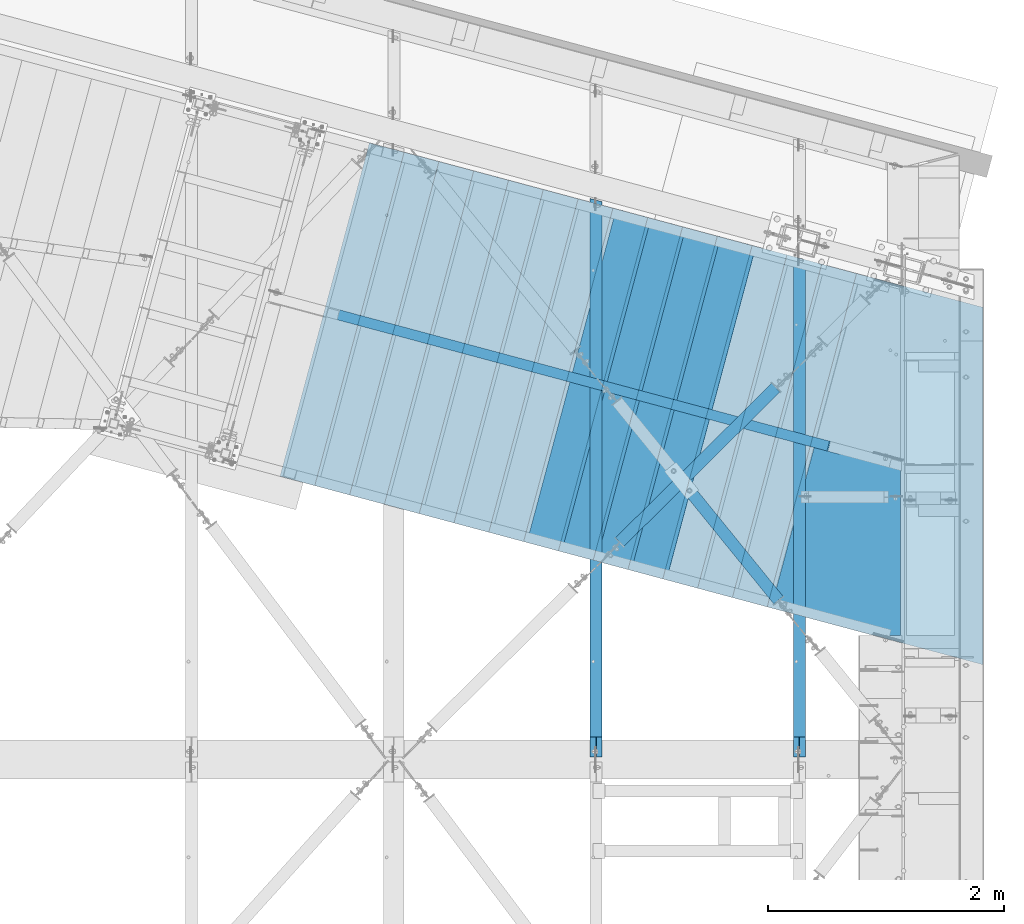
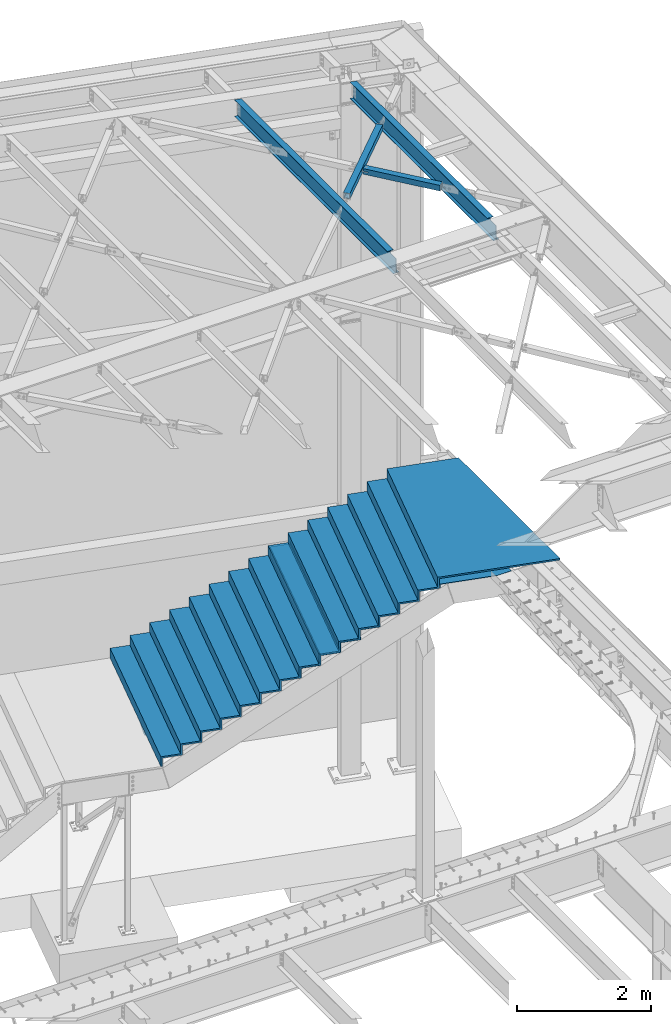
# One storey, part 1170 of 1763: 10 beams, 1 member, 7 elements without a shape of their own.
"""IFC2X3 building model written with IfcOpenShell, lengths in millimetres."""

from ifc_helpers import new_model, si_unit, frame, origin_with_axes, place, context, subcontext, project, spatial, faceted_brep, material, type_object, element, aggregate, save


model = new_model("IFC2X3")

# Units and contexts
model_context = context("Model", 3, precision=1e-05, world=origin_with_axes())
body_context = subcontext(model_context, "Body", "Model", "MODEL_VIEW")
ifc_project = project(units=[si_unit("LENGTHUNIT", "METRE", prefix="MILLI"), si_unit("AREAUNIT", "SQUARE_METRE"), si_unit("VOLUMEUNIT", "CUBIC_METRE"), si_unit("MASSUNIT", "GRAM", prefix="KILO"), si_unit("TIMEUNIT", "SECOND"), si_unit("PLANEANGLEUNIT", "RADIAN"), si_unit("SOLIDANGLEUNIT", "STERADIAN"), si_unit("THERMODYNAMICTEMPERATUREUNIT", "DEGREE_CELSIUS"), si_unit("LUMINOUSINTENSITYUNIT", "LUMEN")], contexts=[model_context])

# Site, building, storey
site_placement = place(None, origin_with_axes())
site = spatial("IfcSite", under=ifc_project, at=site_placement, CompositionType="ELEMENT")
building_placement = place(site_placement, origin_with_axes())
building = spatial("IfcBuilding", under=site, at=building_placement, Name="Undefined", CompositionType="ELEMENT")
storey_placement = place(building_placement, origin_with_axes())
storey = spatial("IfcBuildingStorey", under=building, at=storey_placement, Name="Undefined", CompositionType="ELEMENT", Elevation=0.0)

# Assembly, beam
assembly_1_placement = place(storey_placement, origin_with_axes())
assembly_1 = element("IfcElementAssembly", 1, at=assembly_1_placement, inside=storey, Name="BENT_PLATE", AssemblyPlace="NOTDEFINED", PredefinedType="RIGID_FRAME")
ifc_material_1 = material(Name="STEEL/A36")
beam_type_1 = type_object("IfcBeamType", PredefinedType="NOTDEFINED")
beam_1_placement = place(assembly_1_placement, frame((-21003.2672409802, 59253.1163155108, 5251.44988239311), z_axis=(-0.258865912030778, -0.965913267114844, 3.00823476209188e-08), x_axis=(0.0, 0.0, -1.0)))
beam_1 = element("IfcBeam", 2, at=beam_1_placement, type_object=beam_type_1, material=ifc_material_1, Name="BENT_PLATE", context=body_context, shape_type="Brep", body=[
    faceted_brep([(57.6506451250798, -1650.94311464479, 720.710372407564), (47.6245760248121, -1650.9436488109, 720.710372254034), (47.6251582457617, -1650.92979207974, -720.73962767957), (57.6501590183007, -1650.93032624145, -720.73962753555), (121.44339776049, -1650.93032622719, -720.739649048715), (121.443883867259, -1650.94311463053, 720.710350894398), (121.443397758396, -1641.40532622756, -720.739564543852), (121.443883865164, -1641.41811463091, 720.710435399262), (57.6501590162061, -1641.40532624182, -720.739543030686), (57.1501590162088, -1641.40479207806, -720.739539327413), (57.1495767952592, -1641.41864880922, 720.710460606191), (57.6506451229843, -1641.41811464516, 720.710456912435), (57.1496481931354, -758.731268997537, 720.718291722325), (47.6246481931375, -758.731253575555, 720.71828787517), (57.1496908737008, -533.074830259327, 660.242095972302), (47.6246908737003, -533.07483026143, 660.242096258822), (47.6252187294413, -903.173937115156, -720.732993662728), (57.15021872944, -903.173936005202, -720.73298981542)], [[[0, 1, 2, 3, 4, 5]], [[5, 4, 6, 7]], [[8, 9, 10, 11, 7, 6]], [[1, 0, 5, 7, 11, 10, 12, 13]], [[13, 12, 14, 15]], [[2, 1, 13, 15, 16]], [[9, 8, 6, 4, 3, 2, 16, 17]], [[12, 10, 9, 17, 14]], [[16, 15, 14, 17]]]),
])
aggregate(assembly_1, [beam_1])

assembly_2_placement = place(storey_placement, origin_with_axes())
assembly_2 = element("IfcElementAssembly", 3, at=assembly_2_placement, inside=storey, Name="H. BRACE", AssemblyPlace="NOTDEFINED", PredefinedType="RIGID_FRAME")
ifc_material_2 = material()
beam_type_2 = type_object("IfcBeamType", Name="HSS4X4X3/8", PredefinedType="NOTDEFINED")
beam_2_placement = place(assembly_2_placement, frame((-24264.6496174484, 59345.3336021854, 12371.3875), z_axis=(0.0, 0.0, 1.0), x_axis=(0.711007281992602, 0.703184644992688, 0.0)))
beam_2 = element("IfcBeam", 4, at=beam_2_placement, type_object=beam_type_2, material=ifc_material_2, Name="H. BRACE", ObjectType="HSS4X4X3/8", context=body_context, shape_type="Brep", body=[
    faceted_brep([(950.85467057893, 50.799999998344, 6.35000000000218), (949.917828152189, 41.2749999983498, 6.35000000000218), (949.917828152189, 41.2749999983498, -6.34999999999854), (950.85467057893, 50.799999998344, -6.34999999999854), (1090.2919366415, 41.2749999981024, -6.34999999999854), (1091.22877922558, 50.7999999981039, -6.34999999999854), (1090.2919366415, 41.2749999981024, 6.35000000000218), (1091.22877922558, 50.7999999981039, 6.35000000000218), (941.798527120362, -41.2750000016822, 6.35000000000218), (940.861684693613, -50.8000000016764, 6.35000000000218), (940.861684693613, -50.8000000016764, -6.34999999999854), (941.798527120362, -41.2750000016822, -6.34999999999854), (1081.23579166203, -50.800000001931, -6.34999999999854), (1082.17263424611, -41.2750000019296, -6.34999999999854), (1081.23579166203, -50.800000001931, 6.35000000000218), (1082.17263424611, -41.2750000019296, 6.35000000000218), (280.742643683188, -50.8000000005195, -50.7999999999993), (280.742643682926, 50.7999999995227, -50.7999999999993), (2136.20681555194, 50.7999999962631, -50.7999999999993), (2136.2068155522, -50.8000000037864, -50.7999999999993), (280.742643682926, 50.7999999995227, 50.7999999999993), (280.742643683188, -50.8000000005195, 50.7999999999993), (2136.2068155522, -50.8000000037864, 50.7999999999993), (2136.20681555194, 50.7999999962631, 50.7999999999993), (280.742643682952, 41.2749999995285, 41.2749999999996), (280.742643683163, -41.275000000518, 41.2749999999996), (280.742643683163, -41.275000000518, -41.2749999999996), (280.742643682952, 41.2749999995285, -41.2749999999996), (2136.20681555197, 41.2749999962543, -41.2749999999996), (2136.20681555197, 41.2749999962543, 41.2749999999996), (2136.20681555218, -41.275000003785, 41.2749999999996), (2136.20681555218, -41.275000003785, -41.2749999999996)], [[[0, 1, 2, 3]], [[3, 2, 4, 5]], [[5, 4, 6, 7]], [[7, 6, 1, 0]], [[8, 9, 10, 11]], [[11, 10, 12, 13]], [[13, 12, 14, 15]], [[15, 14, 9, 8]], [[16, 17, 18, 19]], [[20, 21, 22, 23]], [[17, 20, 23, 18], [3, 5, 7, 0]], [[16, 21, 20, 17], [24, 25, 26, 27]], [[24, 27, 28, 29], [2, 1, 6, 4]], [[25, 24, 29, 30]], [[26, 25, 30, 31], [11, 13, 15, 8]], [[27, 26, 31, 28]], [[22, 19, 18, 23], [30, 29, 28, 31]], [[21, 16, 19, 22], [10, 9, 14, 12]]]),
])
aggregate(assembly_2, [beam_2])

assembly_3_placement = place(storey_placement, origin_with_axes())
assembly_3 = element("IfcElementAssembly", 5, at=assembly_3_placement, inside=storey, Name="H. BRACE", AssemblyPlace="NOTDEFINED", PredefinedType="RIGID_FRAME")
beam_3_placement = place(assembly_3_placement, frame((-22546.3296174484, 58832.8427732481, 12371.3875), z_axis=(0.0, 0.0, 1.0), x_axis=(-0.630211709758953, 0.776423338702989, 0.0)))
beam_3 = element("IfcBeam", 6, at=beam_3_placement, type_object=beam_type_2, material=ifc_material_2, Name="H. BRACE", ObjectType="HSS4X4X3/8", context=body_context, shape_type="Brep", body=[
    faceted_brep([(1511.46674810058, -50.8000000034663, -6.35000000000036), (1511.46674810056, -41.2750000034757, -6.35000000000036), (1426.2821400689, -41.2750000032756, -6.35000000000036), (1426.28213914244, -50.8000000032662, -6.35000000000036), (1426.2821400689, -41.2750000032756, 6.35000000000036), (1426.28213914244, -50.8000000032662, 6.35000000000036), (1511.46674810058, -50.8000000034663, 6.35000000000036), (1511.46674810056, -41.2750000034757, 6.35000000000036), (1511.46674810037, 41.2749999964653, -6.35000000000036), (1511.46674810035, 50.7999999964522, -6.35000000000036), (1426.28214902463, 50.799999996656, -6.35000000000036), (1426.28214809817, 41.2749999966654, -6.35000000000036), (1426.28214902463, 50.799999996656, 6.35000000000036), (1426.28214809817, 41.2749999966654, 6.35000000000036), (1511.46674810037, 41.2749999964653, 6.35000000000036), (1511.46674810035, 50.7999999964522, 6.35000000000036), (281.348620558667, -41.2750000006235, 41.2749999999996), (281.348620558478, 41.2749999993139, 41.2749999999996), (1511.46674810037, 41.2749999964653, 41.2749999999996), (1511.46674810056, -41.2750000034757, 41.2749999999996), (1511.46674810056, -41.2750000034757, -41.2749999999996), (281.348620558667, -41.2750000006235, -41.2749999999996), (281.348620558478, 41.2749999993139, -41.2749999999996), (1511.46674810037, 41.2749999964653, -41.2749999999996), (281.348620558689, -50.8000000006214, -50.7999999999993), (281.348620558689, -50.8000000006214, 50.7999999999993), (281.348620558456, 50.7999999993044, 50.7999999999993), (281.348620558456, 50.7999999993044, -50.7999999999993), (1511.46674810058, -50.8000000034663, 50.7999999999993), (1511.46674810035, 50.7999999964522, 50.7999999999993), (1511.46674810035, 50.7999999964522, -50.7999999999993), (1511.46674810058, -50.8000000034663, -50.7999999999993)], [[[0, 1, 2, 3]], [[3, 2, 4, 5]], [[6, 5, 4, 7]], [[8, 9, 10, 11]], [[11, 10, 12, 13]], [[14, 13, 12, 15]], [[16, 17, 18, 19]], [[2, 1, 20, 21, 16, 19, 7, 4]], [[22, 21, 20, 23]], [[24, 25, 26, 27], [17, 16, 21, 22]], [[26, 25, 28, 29]], [[19, 18, 14, 15, 29, 28, 6, 7]], [[10, 9, 30, 27, 26, 29, 15, 12]], [[24, 27, 30, 31]], [[28, 25, 24, 31, 0, 3, 5, 6]], [[31, 30, 9, 8, 23, 20, 1, 0]], [[18, 17, 22, 23, 8, 11, 13, 14]]]),
])
aggregate(assembly_3, [beam_3])

# Assembly, member
assembly_4_placement = place(storey_placement, origin_with_axes())
assembly_4 = element("IfcElementAssembly", 7, at=assembly_4_placement, inside=storey, Name="STRINGER", AssemblyPlace="NOTDEFINED", PredefinedType="RIGID_FRAME")
member_type = type_object("IfcMemberType", Name="C15X33.9", PredefinedType="NOTDEFINED")
member_placement = place(assembly_4_placement, frame((-21969.937005167, 60264.8820691465, 5169.45011935172), z_axis=(0.486695708763338, -0.13043503320458, -0.863778900636194), x_axis=(-0.834335499956352, 0.223602912988303, -0.50387102597364)))
member = element("IfcMember", 8, at=member_placement, type_object=member_type, material=ifc_material_1, Name="STRINGER", ObjectType="C15X33.9", context=body_context, shape_type="Brep", body=[
    faceted_brep([(377.770677480883, -40.096616847979, 181.305096366556), (377.770677497621, 33.3374999985899, 181.305096366563), (374.463192616367, 33.3374999986336, 169.070972499958), (5371.12157756641, -40.0966168786908, -181.305096368524), (5371.12157758316, 33.3374999856896, -181.305096368513), (5374.42906248087, 33.337499985646, -169.070972498947), (5462.11376655698, -42.8625000156244, 190.500000000822), (5468.8001694057, -42.8625000156244, 181.765892500833), (5469.15293224548, -40.0966168798332, 181.305096370408), (5469.15293226223, 33.3374999845473, 181.305096370415), (5462.11376657645, 42.5324036149832, 190.500000000829), (5359.11074327314, 42.532403616191, -190.49999999893), (5358.76879646806, 42.8624999857711, -190.499999998934), (5461.77181977136, 42.8624999845633, 190.500000000833), (5465.84544736449, 33.3374999845837, 169.070972500849), (5370.51966304915, -42.8625000144748, -181.765892498945), (5359.11074325368, -42.8625000144166, -190.499999998941), (286.778488966, -42.8625000004322, -190.499999999829), (280.092086109009, -42.8625000004249, -181.765892499836), (279.739323267782, -40.096616846844, -181.305096366446), (279.739323284521, 33.3374999997395, -181.305096366439), (286.77848898547, 42.532403633144, -190.499999999818), (389.781511800851, 42.5324036319507, 190.499999999945), (390.123458602906, 42.8624999985623, 190.499999999945), (287.120435787525, 42.8624999997628, -190.499999999818), (283.046808165778, 33.3374999997031, -169.070972499834), (378.372592000011, -42.8625000015818, 181.765892499941), (389.781511781377, -42.8625000016327, 190.499999999938)], [[[0, 1, 2]], [[3, 4, 5]], [[6, 7, 8, 9, 10]], [[4, 11, 12, 13, 10, 9, 14, 5]], [[3, 15, 16, 11, 4]], [[17, 18, 19, 20, 21]], [[1, 22, 23, 24, 21, 20, 25, 2]], [[0, 26, 27, 22, 1]], [[24, 23, 13, 12]], [[13, 23, 22, 27, 6, 10]], [[27, 26, 7, 6]], [[26, 0, 2, 14, 8, 7]], [[2, 25, 5, 14]], [[5, 25, 19, 18, 15, 3]], [[18, 17, 16, 15]], [[16, 17, 21, 24, 12, 11]], [[8, 14, 9]], [[19, 25, 20]]]),
])

# Assembly, beam
assembly_5_placement = place(storey_placement, origin_with_axes())
assembly_5 = element("IfcElementAssembly", 9, at=assembly_5_placement, inside=storey, Name="BEAM", AssemblyPlace="NOTDEFINED", PredefinedType="RIGID_FRAME")
ifc_material_3 = material(Name="STEEL/A992")
beam_type_3 = type_object("IfcBeamType", Name="W12X16", PredefinedType="NOTDEFINED")
beam_4_placement = place(assembly_5_placement, frame((-22546.3296174484, 57702.45, 12293.6), z_axis=(0.0, 0.0, 1.0), x_axis=(0.0, 1.0, 0.0)))
beam_4 = element("IfcBeam", 10, at=beam_4_placement, type_object=beam_type_3, material=ifc_material_3, Name="BEAM", ObjectType="W12X16", context=body_context, shape_type="Brep", body=[
    faceted_brep([(179.387500190729, -3.17500000000291, 114.040001678466), (179.387500190729, 3.17500000000291, 114.040001678466), (20.6374999999971, 3.17500000000291, 114.040001678466), (20.6374999999971, -3.17500000000291, 114.040001678466), (184.247579708775, -3.17500000000291, 115.006731601054), (184.247579708775, 3.17500000000291, 115.006731601054), (188.367756176929, -3.17500000000291, 117.759745501531), (188.367756176929, 3.17500000000291, 117.759745501531), (191.120770077403, -3.17500000000291, 121.879921969685), (191.120770077403, 3.17500000000291, 121.879921969685), (192.087499999994, -3.17500000000291, 126.740001487731), (192.087499999994, 3.17500000000291, 126.740001487731), (192.087499999994, -50.8000000000029, 152.4), (192.087499999994, 50.8000000000029, 152.4), (192.087499999994, 50.8000000000029, 146.049999999999), (192.087499999994, 3.17500000000291, 146.049999999999), (192.087499999994, -3.17500000000291, 146.049999999999), (192.087499999994, -50.8000000000029, 146.049999999999), (20.637499999335, -3.17500000023574, -146.050000000019), (20.637499999335, -50.8000000002503, -146.05000000003), (4258.11735211471, -50.7999999999993, -146.049999999999), (4270.88090913396, -3.17499999999927, -146.049999999999), (20.637499999335, -50.8000000002576, -152.400000000032), (4258.11735211471, -50.7999999999993, -152.4), (20.637499999335, 50.7999999997701, -152.400000000003), (4285.34627375577, 50.7999999999993, -152.4), (20.637499999335, 50.7999999997774, -146.050000000005), (20.637499999335, 3.17499999977008, -146.050000000016), (4272.58271673653, 3.17499999999927, -146.049999999999), (4285.34627375577, 50.7999999999993, -146.049999999999), (4272.58271673653, 3.17499999999927, 146.049999999999), (4285.34627375577, 50.7999999999993, 146.049999999999), (4285.34627375577, 50.7999999999993, 152.4), (4258.11735211471, -50.7999999999993, 152.4), (4258.11735211471, -50.7999999999993, 146.049999999999), (4270.88090913396, -3.17499999999927, 146.049999999999)], [[[0, 1, 2, 3]], [[4, 5, 1, 0]], [[6, 7, 5, 4]], [[8, 9, 7, 6]], [[10, 11, 9, 8]], [[12, 13, 14, 15, 11, 10, 16, 17]], [[18, 19, 20, 21]], [[19, 22, 23, 20]], [[22, 24, 25, 23]], [[26, 27, 28, 29]], [[24, 26, 29, 25]], [[28, 30, 31, 32, 33, 34, 35, 21, 20, 23, 25, 29]], [[34, 33, 12, 17]], [[35, 34, 17, 16]], [[8, 6, 4, 0, 3, 18, 21, 35, 16, 10]], [[27, 26, 24, 22, 19, 18, 3, 2]], [[30, 28, 27, 2, 1, 5, 7, 9, 11, 15]], [[31, 30, 15, 14]], [[32, 31, 14, 13]], [[33, 32, 13, 12]]]),
])
aggregate(assembly_5, [beam_4])

assembly_6_placement = place(storey_placement, origin_with_axes())
assembly_6 = element("IfcElementAssembly", 11, at=assembly_6_placement, inside=storey, Name="BEAM", AssemblyPlace="NOTDEFINED", PredefinedType="RIGID_FRAME")
beam_5_placement = place(assembly_6_placement, frame((-24264.6496174484, 57702.45, 12293.6), z_axis=(0.0, 0.0, 1.0), x_axis=(0.0, 1.0, 0.0)))
beam_5 = element("IfcBeam", 12, at=beam_5_placement, type_object=beam_type_3, material=ifc_material_3, Name="BEAM", ObjectType="W12X16", context=body_context, shape_type="Brep", body=[
    faceted_brep([(20.637499999335, -3.17500000023574, -146.050000000019), (20.637499999335, -50.8000000002503, -146.05000000003), (4718.54398888365, -50.7999999999993, -146.049999999999), (4731.30506917194, -3.17499999999927, -146.049999999999), (20.637499999335, -50.8000000002576, -152.400000000032), (4718.54398888365, -50.7999999999993, -152.4), (20.637499999335, 50.7999999997701, -152.400000000003), (4745.76762683201, 50.7999999999993, -152.4), (20.637499999335, 50.7999999997774, -146.050000000005), (4745.76762683201, 50.7999999999993, -146.049999999999), (4733.00654654371, 3.17499999999927, -146.049999999999), (4733.00654654371, 3.17499999999927, 146.049999999999), (4745.76762683201, 50.7999999999993, 146.049999999999), (4745.76762683201, 50.7999999999993, 152.4), (4718.54398888365, -50.7999999999993, 152.4), (4718.54398888365, -50.7999999999993, 146.049999999999), (4731.30506917194, -3.17499999999927, 146.049999999999), (20.637499999335, 3.17499999977008, -146.050000000016), (184.247579708775, -3.17500000000291, 115.006731601054), (184.247579708775, 3.17500000000291, 115.006731601054), (179.387500190729, 3.17500000000291, 114.040001678466), (179.387500190729, -3.17500000000291, 114.040001678466), (188.367756176929, -3.17500000000291, 117.759745501531), (188.367756176929, 3.17500000000291, 117.759745501531), (191.120770077403, -3.17500000000291, 121.879921969685), (191.120770077403, 3.17500000000291, 121.879921969685), (192.087499999994, -3.17500000000291, 126.740001487731), (192.087499999994, 3.17500000000291, 126.740001487731), (20.6374999999971, 3.17500000000291, 114.040001678466), (192.087499999994, 3.17500000000291, 146.049999999999), (192.087499999994, 50.8000000000029, 146.049999999999), (192.087499999994, 50.8000000000029, 152.4), (192.087499999994, -50.8000000000029, 152.4), (192.087499999994, -50.8000000000029, 146.049999999999), (192.087499999994, -3.17500000000291, 146.049999999999), (20.6374999999971, -3.17500000000291, 114.040001678466)], [[[0, 1, 2, 3]], [[1, 4, 5, 2]], [[4, 6, 7, 5]], [[6, 8, 9, 7]], [[10, 11, 12, 13, 14, 15, 16, 3, 2, 5, 7, 9]], [[8, 17, 10, 9]], [[18, 19, 20, 21]], [[22, 23, 19, 18]], [[24, 25, 23, 22]], [[26, 27, 25, 24]], [[11, 10, 17, 28, 20, 19, 23, 25, 27, 29]], [[12, 11, 29, 30]], [[13, 12, 30, 31]], [[14, 13, 31, 32]], [[15, 14, 32, 33]], [[16, 15, 33, 34]], [[32, 31, 30, 29, 27, 26, 34, 33]], [[24, 22, 18, 21, 35, 0, 3, 16, 34, 26]], [[17, 8, 6, 4, 1, 0, 35, 28]], [[21, 20, 28, 35]]]),
])
aggregate(assembly_6, [beam_5])

# Beam
beam_type_4 = type_object("IfcBeamType", PredefinedType="NOTDEFINED")
beam_6_placement = place(assembly_4_placement, frame((-23291.2087596942, 60632.0165994589, 4641.85004577672), z_axis=(-0.258865912030778, -0.965913267114844, 3.00823476209188e-08), x_axis=(0.0, 0.0, -1.0)))
beam_6 = element("IfcBeam", 13, at=beam_6_placement, type_object=beam_type_4, material=ifc_material_1, Name="BENT_PLATE", context=body_context, shape_type="Brep", body=[
    faceted_brep([(1.9117578631267e-09, -1.5875000009255, -1460.49999999993), (-1.18325260700658e-09, -1.58749999909924, 1460.49999999992), (-1.9117578631267e-09, 1.58750000090367, 1460.49999999991), (1.18234311230481e-09, 1.58749999907741, -1460.49999999993), (50.7999999972071, 1.58750001260341, 1460.50000000007), (50.800000002233, 1.58750001077715, -1460.49999999979), (47.6250000029295, -1.58749998995336, -1460.4999999998), (47.6249999979027, -1.58749998812709, 1460.50000000005), (50.8000000657603, -306.387503397986, 1460.50000000045), (50.8000000687034, -306.387503401733, -1460.49999999939), (47.6250000693999, -309.562503402434, -1460.4999999994), (47.6250000664559, -309.562503398687, 1460.50000000045), (222.250000065187, -306.387503360114, 1460.50000000094), (222.250000068131, -306.387503363934, -1460.49999999891), (222.250000065887, -309.562503360117, 1460.50000000094), (222.250000068831, -309.562503363937, -1460.4999999989)], [[[0, 1, 2, 3]], [[3, 2, 4, 5]], [[1, 0, 6, 7]], [[5, 4, 8, 9]], [[7, 6, 10, 11]], [[9, 8, 12, 13]], [[8, 4, 2, 1, 7, 11, 14, 12]], [[11, 10, 15, 14]], [[10, 6, 0, 3, 5, 9, 13, 15]], [[14, 15, 13, 12]]]),
])

beam_7_placement = place(assembly_4_placement, frame((-23585.6191610753, 60710.918939513, 4464.04999694859), z_axis=(-0.258865912030778, -0.965913267114844, 3.00823476209188e-08), x_axis=(0.0, 0.0, -1.0)))
beam_7 = element("IfcBeam", 14, at=beam_7_placement, type_object=beam_type_4, material=ifc_material_1, Name="BENT_PLATE", context=body_context, shape_type="Brep", body=[
    faceted_brep([(1.9117578631267e-09, -1.5875000009255, -1460.49999999993), (-1.18325260700658e-09, -1.58749999909924, 1460.49999999992), (-1.9117578631267e-09, 1.58750000090367, 1460.49999999991), (1.18234311230481e-09, 1.58749999907741, -1460.49999999993), (50.7999999972071, 1.58750001260341, 1460.50000000007), (50.800000002233, 1.58750001077715, -1460.49999999979), (47.6250000029295, -1.58749998995336, -1460.4999999998), (47.6249999979027, -1.58749998812709, 1460.50000000005), (50.8000000657603, -306.387503397986, 1460.50000000045), (50.8000000687034, -306.387503401733, -1460.49999999939), (47.6250000693999, -309.562503402434, -1460.4999999994), (47.6250000664559, -309.562503398687, 1460.50000000045), (222.250000065187, -306.387503360114, 1460.50000000094), (222.250000068131, -306.387503363934, -1460.49999999891), (222.250000065887, -309.562503360117, 1460.50000000094), (222.250000068831, -309.562503363937, -1460.4999999989)], [[[0, 1, 2, 3]], [[3, 2, 4, 5]], [[1, 0, 6, 7]], [[5, 4, 8, 9]], [[7, 6, 10, 11]], [[9, 8, 12, 13]], [[8, 4, 2, 1, 7, 11, 14, 12]], [[11, 10, 15, 14]], [[10, 6, 0, 3, 5, 9, 13, 15]], [[14, 15, 13, 12]]]),
])

beam_8_placement = place(assembly_4_placement, frame((-23880.0295624563, 60789.8212795671, 4286.24994812047), z_axis=(-0.258865912030778, -0.965913267114844, 3.00823476209188e-08), x_axis=(0.0, 0.0, -1.0)))
beam_8 = element("IfcBeam", 15, at=beam_8_placement, type_object=beam_type_4, material=ifc_material_1, Name="BENT_PLATE", context=body_context, shape_type="Brep", body=[
    faceted_brep([(1.9117578631267e-09, -1.5875000009255, -1460.49999999993), (-1.18325260700658e-09, -1.58749999909924, 1460.49999999992), (-1.9117578631267e-09, 1.58750000090367, 1460.49999999991), (1.18234311230481e-09, 1.58749999907741, -1460.49999999993), (50.7999999972071, 1.58750001260341, 1460.50000000007), (50.800000002233, 1.58750001077715, -1460.49999999979), (47.6250000029295, -1.58749998995336, -1460.4999999998), (47.6249999979027, -1.58749998812709, 1460.50000000005), (50.8000000657603, -306.387503397986, 1460.50000000045), (50.8000000687034, -306.387503401733, -1460.49999999939), (47.6250000693999, -309.562503402434, -1460.4999999994), (47.6250000664559, -309.562503398687, 1460.50000000045), (222.250000065187, -306.387503360114, 1460.50000000094), (222.250000068131, -306.387503363934, -1460.49999999891), (222.250000065887, -309.562503360117, 1460.50000000094), (222.250000068831, -309.562503363937, -1460.4999999989)], [[[0, 1, 2, 3]], [[3, 2, 4, 5]], [[1, 0, 6, 7]], [[5, 4, 8, 9]], [[7, 6, 10, 11]], [[9, 8, 12, 13]], [[8, 4, 2, 1, 7, 11, 14, 12]], [[11, 10, 15, 14]], [[10, 6, 0, 3, 5, 9, 13, 15]], [[14, 15, 13, 12]]]),
])

beam_9_placement = place(assembly_4_placement, frame((-24174.4399638373, 60868.7236196212, 4108.45002136266), z_axis=(-0.258865912030778, -0.965913267114844, 3.00823476209188e-08), x_axis=(0.0, 0.0, -1.0)))
beam_9 = element("IfcBeam", 16, at=beam_9_placement, type_object=beam_type_4, material=ifc_material_1, Name="BENT_PLATE", context=body_context, shape_type="Brep", body=[
    faceted_brep([(1.9117578631267e-09, -1.5875000009255, -1460.49999999993), (-1.18325260700658e-09, -1.58749999909924, 1460.49999999992), (-1.9117578631267e-09, 1.58750000090367, 1460.49999999991), (1.18234311230481e-09, 1.58749999907741, -1460.49999999993), (50.7999999972071, 1.58750001260341, 1460.50000000007), (50.800000002233, 1.58750001077715, -1460.49999999979), (47.6250000029295, -1.58749998995336, -1460.4999999998), (47.6249999979027, -1.58749998812709, 1460.50000000005), (50.8000000657603, -306.387503397986, 1460.50000000045), (50.8000000687034, -306.387503401733, -1460.49999999939), (47.6250000693999, -309.562503402434, -1460.4999999994), (47.6250000664559, -309.562503398687, 1460.50000000045), (222.250000065187, -306.387503360114, 1460.50000000094), (222.250000068131, -306.387503363934, -1460.49999999891), (222.250000065887, -309.562503360117, 1460.50000000094), (222.250000068831, -309.562503363937, -1460.4999999989)], [[[0, 1, 2, 3]], [[3, 2, 4, 5]], [[1, 0, 6, 7]], [[5, 4, 8, 9]], [[7, 6, 10, 11]], [[9, 8, 12, 13]], [[8, 4, 2, 1, 7, 11, 14, 12]], [[11, 10, 15, 14]], [[10, 6, 0, 3, 5, 9, 13, 15]], [[14, 15, 13, 12]]]),
])

aggregate(assembly_4, [beam_6, beam_7, beam_8, beam_9, member])

# Assembly, beam
assembly_7_placement = place(storey_placement, origin_with_axes())
assembly_7 = element("IfcElementAssembly", 17, at=assembly_7_placement, inside=storey, Name="TILE ON CEMENT BOARD", AssemblyPlace="NOTDEFINED", PredefinedType="REINFORCEMENT_UNIT")
ifc_material_4 = material(Name="CONCRETE/3000")
beam_type_5 = type_object("IfcBeamType", PredefinedType="NOTDEFINED")
beam_10_placement = place(assembly_7_placement, frame((-26548.1235446389, 61504.8736608079, 2666.99999694824), z_axis=(-0.258865912030778, -0.965913267114844, 3.00823476209188e-08), x_axis=(0.0, 0.0, 1.0)))
beam_10 = element("IfcBeam", 18, at=beam_10_placement, type_object=beam_type_5, material=ifc_material_4, Name="TILE ON CEMENT BOARD", context=body_context, shape_type="Brep", body=[
    faceted_brep([(2282.82490234439, -3976.68750233371, 1460.49999999742), (2282.82490234439, -3976.68750233178, -1460.50000000243), (2460.62495117249, -3976.68750233184, -1460.50000000243), (2460.62495117255, -3976.68750233366, 1460.49999999742), (2282.82490234441, -3671.88744764369, 1460.49999999761), (2282.82490234438, -3671.88744764187, -1460.50000000224), (2105.02509765689, -3671.88744764369, 1460.49999999761), (2105.02509765689, -3671.88744764187, -1460.50000000224), (2105.02509765689, -3367.08742455357, 1460.4999999978), (2105.02509765689, -3367.08742455174, -1460.50000000204), (1927.22504882877, -3367.08742455355, 1460.4999999978), (1927.22504882877, -3367.08742455176, -1460.50000000204), (1927.22504882872, -3062.28762148219, 1460.49999999799), (1927.22504882881, -3062.28762148037, -1460.50000000186), (1749.42500000064, -3062.28762148218, 1460.49999999798), (1749.42500000064, -3062.28762148038, -1460.50000000186), (1749.42500000069, -2757.48758259216, 1460.49999999818), (1749.42500000059, -2757.48758259033, -1460.50000000167), (1571.62495117252, -2757.48758259218, 1460.49999999819), (1571.62495117252, -2757.4875825903, -1460.50000000166), (1571.62495117252, -2452.68754370211, 1460.49999999838), (1571.62495117252, -2452.68754370028, -1460.50000000147), (1393.8250244147, -2452.68754370209, 1460.49999999838), (1393.8250244147, -2452.6875437003, -1460.50000000147), (1393.82502441469, -2147.88750481207, 1460.49999999856), (1393.82502441472, -2147.88750481023, -1460.50000000128), (1216.02497558658, -2147.88750481207, 1460.49999999856), (1216.02497558658, -2147.88750481023, -1460.50000000128), (1216.02497558655, -1843.08747382199, 1460.49999999876), (1216.02497558661, -1843.08747382016, -1460.50000000109), (1038.22504882877, -1843.08747382196, 1460.49999999876), (1038.22504882877, -1843.08747382018, -1460.5000000011), (1038.2250488288, -1538.28756074124, 1460.49999999894), (1038.22504882874, -1538.28756073941, -1460.5000000009), (860.425000000642, -1538.28756074126, 1460.49999999894), (860.425000000642, -1538.28756073937, -1460.5000000009), (860.425000000642, -1233.48752185119, 1460.49999999913), (860.425000000642, -1233.48752184936, -1460.50000000071), (682.625012207673, -1233.4875218512, 1460.49999999913), (682.625012207673, -1233.48752184934, -1460.50000000071), (682.62501220769, -928.687486911127, 1460.49999999933), (682.625012207655, -928.687486909294, -1460.50000000052), (504.825024414704, -928.687486911091, 1460.49999999933), (504.825024414704, -928.687486909337, -1460.50000000052), (504.825024414639, -623.887510925721, 1460.49999999951), (504.825024414769, -623.887510923894, -1460.50000000033), (327.025006104157, -623.887510925728, 1460.49999999951), (327.025006104157, -623.887510923894, -1460.50000000033), (327.025006104192, -319.087505463001, 1460.49999999971), (327.025006104122, -319.087505461168, -1460.50000000014), (149.2250030524, -319.087505463001, 1460.49999999971), (149.2250030524, -319.087505461168, -1460.50000000014), (149.225003052432, -14.2875000008353, 1460.4999999999), (149.225003052367, -14.287499999009, -1460.49999999995), (2.20461515709758e-09, -14.2874999999999, 1460.50000000354), (-2.20461515709758e-09, -14.2874999999999, -1460.50000000354), (2.20461515709758e-09, 14.2874999999999, 1460.50000000354), (-2.20461515709758e-09, 14.2874999999999, -1460.50000000354), (177.800003052432, 14.2874999991836, 1460.49999999992), (177.800003052367, 14.2875000010099, -1460.49999999993), (177.800003052399, -290.512505462997, 1460.49999999972), (177.800003052399, -290.512505461171, -1460.50000000012), (355.600006104192, -290.512505462997, 1460.49999999972), (355.600006104123, -290.512505461171, -1460.50000000012), (355.600006104157, -595.312510925731, 1460.49999999953), (355.600006104157, -595.31251092389, -1460.50000000032), (533.40002441464, -595.312510925723, 1460.49999999953), (533.400024414769, -595.31251092389, -1460.50000000031), (533.400024414704, -900.112486911094, 1460.49999999935), (533.400024414704, -900.112486909333, -1460.5000000005), (711.200012207691, -900.11248691113, 1460.49999999935), (711.200012207656, -900.112486909304, -1460.5000000005), (711.200012207673, -1204.91252185121, 1460.49999999916), (711.200012207673, -1204.91252184934, -1460.5000000007), (889.000000000642, -1204.91252185119, 1460.49999999916), (889.000000000642, -1204.91252184936, -1460.50000000069), (889.000000000642, -1509.71256074127, 1460.49999999897), (889.000000000642, -1509.71256073938, -1460.50000000088), (1066.8000488288, -1509.71256074123, 1460.49999999896), (1066.80004882874, -1509.7125607394, -1460.50000000089), (1066.80004882877, -1814.51247382195, 1460.49999999876), (1066.80004882877, -1814.51247382018, -1460.50000000108), (1244.59997558655, -1814.51247382198, 1460.49999999877), (1244.59997558661, -1814.51247382016, -1460.50000000108), (1244.59997558658, -2119.31250481206, 1460.49999999859), (1244.59997558658, -2119.31250481024, -1460.50000000127), (1422.40002441469, -2119.31250481206, 1460.49999999859), (1422.40002441472, -2119.31250481024, -1460.50000000127), (1422.4000244147, -2424.1125437021, 1460.4999999984), (1422.4000244147, -2424.1125437003, -1460.50000000146), (1600.19995117252, -2424.11254370211, 1460.4999999984), (1600.19995117252, -2424.11254370028, -1460.50000000145), (1600.19995117252, -2728.91258259218, 1460.4999999982), (1600.19995117252, -2728.9125825903, -1460.50000000164), (1778.00000000069, -2728.91258259216, 1460.4999999982), (1778.00000000059, -2728.91258259033, -1460.50000000164), (1778.00000000064, -3033.71262148218, 1460.49999999801), (1778.00000000064, -3033.71262148037, -1460.50000000184), (1955.80004882872, -3033.71262148219, 1460.49999999801), (1955.80004882881, -3033.71262148036, -1460.50000000184), (1955.80004882877, -3338.51242455356, 1460.49999999782), (1955.80004882877, -3338.51242455176, -1460.50000000203), (2133.60009765689, -3338.51242455357, 1460.49999999782), (2133.60009765689, -3338.51242455174, -1460.50000000202), (2133.60009765689, -3643.31244764369, 1460.49999999763), (2133.60009765689, -3643.31244764187, -1460.50000000222), (2311.39990234441, -3643.31244764369, 1460.49999999763), (2311.39990234437, -3643.31244764187, -1460.50000000222), (2311.39990234439, -3948.11250233372, 1460.49999999744), (2311.39990234439, -3948.11250233179, -1460.5000000024), (2489.19995117255, -3948.11250233366, 1460.49999999744), (2489.19995117249, -3948.11250233184, -1460.50000000241), (2489.19995117252, -4252.91250962384, 1460.49999999724), (2489.19995117252, -4252.91250962207, -1460.5000000026), (2667.00000000061, -4252.91250962387, 1460.49999999725), (2667.00000000067, -4252.91250962204, -1460.5000000026), (2667.00000000063, -6141.78603301747, 1460.49999999606), (2667.00000000066, -5358.95453583726, -1460.50000000329), (2638.42500000067, -4281.48750962204, -1460.50000000262), (2460.62495117252, -4281.48750962207, -1460.50000000262), (2638.42500000066, -5358.95453583726, -1460.50000000329), (2460.62495117252, -4281.48750962384, 1460.49999999723), (2638.42500000061, -4281.48750962387, 1460.49999999723), (2638.42500000063, -6141.78603301747, 1460.49999999606)], [[[0, 1, 2, 3]], [[4, 5, 1, 0]], [[6, 7, 5, 4]], [[8, 9, 7, 6]], [[10, 11, 9, 8]], [[12, 13, 11, 10]], [[14, 15, 13, 12]], [[16, 17, 15, 14]], [[18, 19, 17, 16]], [[20, 21, 19, 18]], [[22, 23, 21, 20]], [[24, 25, 23, 22]], [[26, 27, 25, 24]], [[28, 29, 27, 26]], [[30, 31, 29, 28]], [[32, 33, 31, 30]], [[34, 35, 33, 32]], [[36, 37, 35, 34]], [[38, 39, 37, 36]], [[40, 41, 39, 38]], [[42, 43, 41, 40]], [[44, 45, 43, 42]], [[46, 47, 45, 44]], [[48, 49, 47, 46]], [[50, 51, 49, 48]], [[52, 53, 51, 50]], [[54, 55, 53, 52]], [[55, 54, 56, 57]], [[57, 56, 58, 59]], [[59, 58, 60, 61]], [[61, 60, 62, 63]], [[63, 62, 64, 65]], [[65, 64, 66, 67]], [[67, 66, 68, 69]], [[69, 68, 70, 71]], [[71, 70, 72, 73]], [[73, 72, 74, 75]], [[75, 74, 76, 77]], [[77, 76, 78, 79]], [[79, 78, 80, 81]], [[81, 80, 82, 83]], [[83, 82, 84, 85]], [[85, 84, 86, 87]], [[87, 86, 88, 89]], [[89, 88, 90, 91]], [[91, 90, 92, 93]], [[93, 92, 94, 95]], [[95, 94, 96, 97]], [[97, 96, 98, 99]], [[99, 98, 100, 101]], [[101, 100, 102, 103]], [[103, 102, 104, 105]], [[105, 104, 106, 107]], [[107, 106, 108, 109]], [[109, 108, 110, 111]], [[111, 110, 112, 113]], [[113, 112, 114, 115]], [[115, 114, 116, 117]], [[118, 119, 2, 1, 5, 7, 9, 11, 13, 15, 17, 19, 21, 23, 25, 27, 29, 31, 33, 35, 37, 39, 41, 43, 45, 47, 49, 51, 53, 55, 57, 59, 61, 63, 65, 67, 69, 71, 73, 75, 77, 79, 81, 83, 85, 87, 89, 91, 93, 95, 97, 99, 101, 103, 105, 107, 109, 111, 113, 115, 117, 120]], [[3, 2, 119, 121]], [[114, 112, 110, 108, 106, 104, 102, 100, 98, 96, 94, 92, 90, 88, 86, 84, 82, 80, 78, 76, 74, 72, 70, 68, 66, 64, 62, 60, 58, 56, 54, 52, 50, 48, 46, 44, 42, 40, 38, 36, 34, 32, 30, 28, 26, 24, 22, 20, 18, 16, 14, 12, 10, 8, 6, 4, 0, 3, 121, 122, 123, 116]], [[120, 117, 116, 123]], [[122, 118, 120, 123]], [[121, 119, 118, 122]]]),
])
aggregate(assembly_7, [beam_10])

save(model, "model.ifc")
